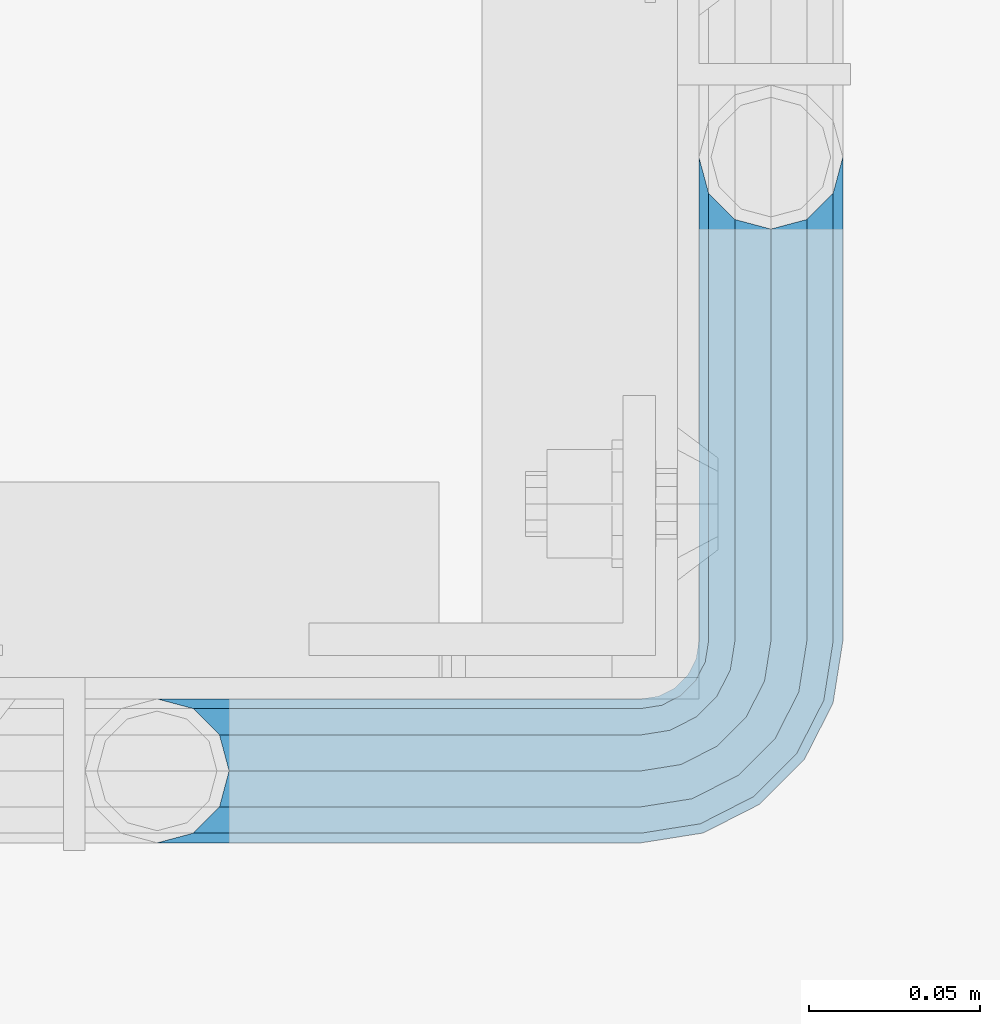
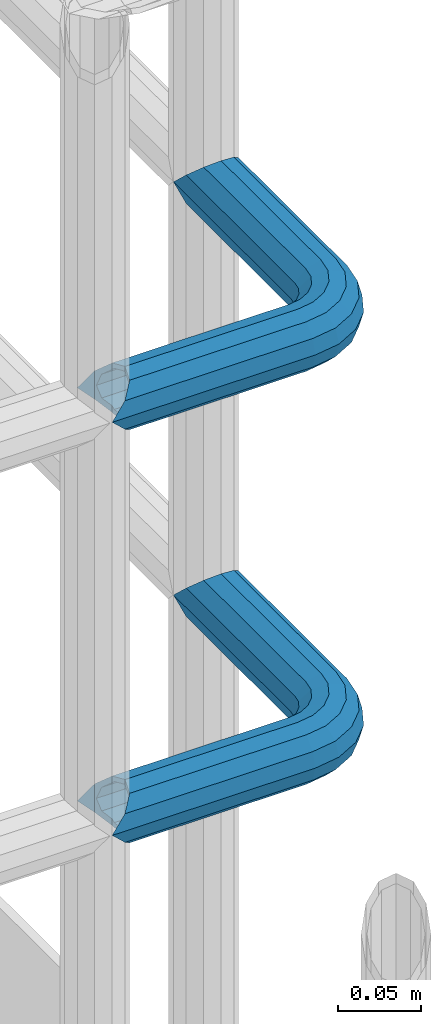
# One storey, part 1119 of 1876: 2 beams, 1 element without a shape of its own.
"""IFC2X3 building model written with IfcOpenShell, lengths in millimetres."""

from ifc_helpers import new_model, si_unit, frame, origin_with_axes, place, context, subcontext, project, spatial, faceted_brep, material, type_object, element, aggregate, save


model = new_model("IFC2X3")

# Units and contexts
model_context = context("Model", 3, precision=1e-05, world=origin_with_axes())
body_context = subcontext(model_context, "Body", "Model", "MODEL_VIEW")
ifc_project = project(units=[si_unit("LENGTHUNIT", "METRE", prefix="MILLI"), si_unit("AREAUNIT", "SQUARE_METRE"), si_unit("VOLUMEUNIT", "CUBIC_METRE"), si_unit("MASSUNIT", "GRAM", prefix="KILO"), si_unit("TIMEUNIT", "SECOND"), si_unit("PLANEANGLEUNIT", "RADIAN"), si_unit("SOLIDANGLEUNIT", "STERADIAN"), si_unit("THERMODYNAMICTEMPERATUREUNIT", "DEGREE_CELSIUS"), si_unit("LUMINOUSINTENSITYUNIT", "LUMEN")], contexts=[model_context])

# Site, building, storey
site_placement = place(None, origin_with_axes())
site = spatial("IfcSite", under=ifc_project, at=site_placement, CompositionType="ELEMENT")
building_placement = place(site_placement, origin_with_axes())
building = spatial("IfcBuilding", under=site, at=building_placement, Name="Undefined", CompositionType="ELEMENT")
storey_placement = place(building_placement, origin_with_axes())
storey = spatial("IfcBuildingStorey", under=building, at=storey_placement, Name="Undefined", CompositionType="ELEMENT", Elevation=0.0)

# Assembly, beams
assembly_placement = place(storey_placement, origin_with_axes())
assembly = element("IfcElementAssembly", 1, at=assembly_placement, inside=storey, Name="HANDRAIL", AssemblyPlace="NOTDEFINED", PredefinedType="RIGID_FRAME")
ifc_material = material()
beam_type = type_object("IfcBeamType", Name="PIPE1-1/4STD", PredefinedType="NOTDEFINED")
beam_1_placement = place(assembly_placement, frame((6845.30474593762, -11381.1963554687, 8480.425), z_axis=(0.0, 0.0, -1.0), x_axis=(1.0, 0.0, 0.0)))
beam_1 = element("IfcBeam", 2, at=beam_1_placement, type_object=beam_type, material=ifc_material, Name="HANDRAIL", ObjectType="PIPE1-1/4STD", context=body_context, shape_type="Brep", body=[
    faceted_brep([(158.747132080079, -179.832000732422, 1.81898940354586e-12), (161.571584517495, -169.290999999999, -10.5409999999974), (161.571584517495, -169.290999999999, 10.5410000000029), (188.592132080079, -161.098037455637, -15.1779612267237), (179.829132080079, -158.749999999998, -17.525999999998), (179.829132080079, -158.749999999998, -21.0819999999985), (190.370132080079, -161.574452437415, -18.2575475625817), (190.370136997563, -161.574452437415, -13.3999563092402), (171.066132080079, -161.098040090908, -15.1779612267237), (169.288136997563, -161.574452437415, -13.3999661442085), (169.288132080079, -161.574452437415, -18.2575475625817), (164.651170853354, -166.211418581624, -8.76299999999719), (162.303132080079, -168.559457354899, 1.81898940354586e-12), (164.651170853354, -166.211418581624, 8.76300000000265), (169.288136997563, -161.574452437415, 13.3999661442122), (169.288132080079, -161.574452437415, 18.2575475625854), (171.066132080079, -161.098040090908, 15.1779612267292), (179.829132080079, -158.749999999998, 17.5260000000017), (179.829132080079, -158.749999999998, 21.0820000000022), (188.592132080079, -161.098037455637, 15.1779612267292), (190.370136997563, -161.574452437415, 13.3999563092439), (190.370132080079, -161.574452437415, 18.2575475625854), (200.911136997564, -179.831999999999, 1.81898940354586e-12), (198.086679642663, -169.290999999999, 10.5410000000029), (198.086679642663, -169.290999999999, -10.5409999999974), (195.007093306805, -166.211408746656, 8.76300000000265), (197.355132080079, -168.55944751993, 1.81898940354586e-12), (195.007093306805, -166.211408746656, -8.76299999999719), (141.729133605959, 21.0819999999967, 3.63797880709171e-12), (141.72913360596, 18.2575475625799, -10.5409999999956), (10.5409999957128, 18.2575475579433, -10.5409999999993), (9.09494701772928e-13, 21.0820000000003, 0.0), (10.5409999999983, 18.2575475625836, 10.5410000000011), (141.729133605959, 18.2575475625799, 10.5410000000047), (141.729133605959, 10.5409999999974, 18.2575475625872), (18.2575475625817, 10.5409999999993, 18.2575475625836), (141.729133605958, -3.63797880709171e-12, 21.082000000004), (21.0819999999985, 1.81898940354586e-12, 21.0820000000003), (141.729133605958, -21.0820000000022, 3.63797880709171e-12), (141.729133605959, -18.2575475625872, -10.5409999999956), (147.860788147674, -19.2287062354389, -10.5409999999956), (146.987984344709, -21.9149201310101, 3.63797880709171e-12), (141.729133605958, -18.2575475625872, 10.5410000000047), (147.860788147674, -19.2287062354389, 10.5410000000047), (141.729133605958, -10.5410000000029, 18.2575475625872), (150.245332482414, -11.8898333927427, 18.2575475625872), (153.50268062012, -1.86474665447531, 21.082000000004), (156.760028757826, 8.16034008379211, 18.257547562589), (159.144573092567, 15.4992129264883, 10.5410000000047), (160.017376895533, 18.1854268220595, 5.45696821063757e-12), (159.144573092567, 15.4992129264883, -10.5409999999956), (141.72913360596, 10.5409999999974, -18.2575475625799), (156.760028757827, 8.16034008379211, -18.2575475625781), (141.729133605959, -3.63797880709171e-12, -21.0819999999949), (153.502680620121, -1.86474665447531, -21.0819999999949), (141.729133605959, -10.5410000000029, -18.2575475625799), (150.245332482415, -11.8898333927427, -18.2575475625781), (190.370132080081, -38.0999984741229, -18.2575475625781), (198.086679642664, -38.0999984741247, -10.5409999999956), (179.829132080081, -38.0999984741229, -21.0819999999949), (169.288132080081, -38.0999984741247, -18.2575475625781), (161.571584517497, -38.0999984741247, -10.5409999999956), (158.747132080079, -38.0999984741247, 5.45696821063757e-12), (161.571584517496, -38.0999984741247, 10.5410000000047), (169.28813208008, -38.0999984741247, 18.257547562589), (179.82913208008, -38.0999984741247, 21.082000000004), (190.37013208008, -38.0999984741247, 18.257547562589), (198.086679642664, -38.0999984741247, 10.5410000000047), (200.91113208008, -38.0999984741247, 5.45696821063757e-12), (198.014558902142, -19.8117551845498, 5.45696821063757e-12), (195.328345006572, -20.6845589875156, -10.5409999999938), (195.328345006572, -20.6845589875156, 10.5410000000047), (187.989472163875, -23.0691033222574, 18.257547562589), (177.964385425607, -26.3264514599632, 21.0820000000058), (167.93929868734, -29.583799597669, 18.257547562589), (160.600425844644, -31.968343932409, 10.5410000000047), (157.914211949073, -32.8411477353748, 5.45696821063757e-12), (160.600425844644, -31.968343932409, -10.5409999999956), (167.939298687341, -29.583799597669, -18.2575475625781), (177.964385425608, -26.3264514599614, -21.0819999999949), (187.989472163876, -23.0691033222556, -18.2575475625781), (187.323346110924, -4.97386405835823, -10.5409999999938), (181.080527994891, -9.50953691425821, -18.2575475625781), (189.608376132597, -3.31369256984362, 5.45696821063757e-12), (187.323346110923, -4.97386405835823, 10.5410000000047), (181.08052799489, -9.50953691425821, 18.257547562589), (172.552679857184, -15.7053812586728, 21.0820000000058), (164.024831719476, -21.9012256030874, 18.257547562589), (157.782013603444, -26.4368984589855, 10.5410000000047), (155.49698358177, -28.0970699475001, 5.45696821063757e-12), (157.782013603444, -26.4368984589855, -10.5409999999956), (164.024831719477, -21.9012256030855, -18.2575475625781), (172.552679857185, -15.705381258671, -21.0819999999949), (170.319595165825, 1.25139591480729, -18.2575475625781), (164.123750821412, -7.27645222289902, -21.0819999999949), (174.855268021725, 7.49421403083943, -10.5409999999956), (176.51543951024, 9.7792440525136, 5.45696821063757e-12), (174.855268021724, 7.49421403083943, 10.5410000000047), (170.319595165825, 1.25139591480729, 18.257547562589), (164.123750821411, -7.27645222289902, 21.0820000000058), (157.927906476996, -15.8043003606053, 18.257547562589), (153.392233621096, -22.0471184766393, 10.5410000000047), (151.732062132583, -24.3321484983135, 3.63797880709171e-12), (153.392233621097, -22.0471184766393, -10.5409999999956), (157.927906476997, -15.8043003606053, -18.2575475625781), (10.5409999957128, -18.2575475672238, -10.5409999999993), (18.2575475625817, -10.5410000000011, -18.2575475625836), (21.0819999999985, 0.0, -21.0819999999985), (18.2575475625817, 10.5409999999993, -18.2575475625836), (141.72913360596, 8.76299999999719, -15.1779612267219), (141.72913360596, 15.1779612267237, -8.76299999999537), (13.6205863358573, 15.1779612267255, -8.76299999999901), (18.2575475625817, 10.5410000000011, -13.3999612267235), (18.7339612267251, 8.76299999999901, -15.1779612267255), (141.729133605959, 17.525999999998, 3.63797880709171e-12), (11.2725475625839, 17.5259999999998, 0.0), (13.6205863358573, 15.1779612267255, 8.76300000000083), (18.2575475625817, 10.5410000000011, 13.3999612267253), (141.729133605959, 15.1779612267237, 8.76300000000447), (141.729133605959, 8.76299999999719, 15.177961226731), (18.7339612267251, 8.76299999999901, 15.1779612267273), (21.0819999999985, 1.81898940354586e-12, 17.5259999999998), (141.729133605958, -3.63797880709171e-12, 17.5260000000035), (141.729133605958, -8.76300000000265, 15.177961226731), (18.7339612267233, -8.76300000000083, 15.1779612267273), (141.729133605958, -15.1779612267292, 8.76300000000447), (141.729133605958, -17.5260000000035, 3.63797880709171e-12), (11.2725475625793, -17.5259999999998, 0.0), (13.6205863358537, -15.1779612267255, 8.76300000000083), (18.2575475625817, -10.5409999999974, 13.3999612267289), (18.2575475625817, -10.5410000000011, 18.2575475625836), (10.5409999999983, -18.2575475625836, 10.5410000000011), (9.09494701772928e-13, -21.0820000000003, 0.0), (13.6205863358537, -15.1779612267255, -8.76299999999901), (18.2575475625817, -10.5409999999974, -13.3999612267271), (141.729133605959, -15.1779612267292, -8.76299999999537), (141.729133605959, -8.76300000000265, -15.1779612267219), (141.729133605959, -3.63797880709171e-12, -17.5259999999962), (21.0819999999985, 0.0, -17.5259999999998), (18.7339612267233, -8.76300000000083, -15.1779612267255), (153.502680620121, -1.86474665447531, -17.5259999999962), (156.210596541829, 6.46936159781944, -15.1779612267219), (158.192928579143, 12.570352274277, -8.76299999999537), (158.918512463535, 14.8034698501142, 5.45696821063757e-12), (158.192928579142, 12.570352274277, 8.76300000000447), (156.210596541828, 6.46936159781944, 15.177961226731), (153.50268062012, -1.86474665447531, 17.5260000000053), (150.794764698413, -10.1988549067701, 15.177961226731), (148.812432661099, -16.2998455832294, 8.76300000000447), (148.086848776706, -18.5329631590648, 3.63797880709171e-12), (148.812432661099, -16.2998455832294, -8.76299999999537), (150.794764698413, -10.1988549067701, -15.1779612267219), (158.972988655572, -14.3658681446068, -15.1779612267219), (164.123750821412, -7.27645222289902, -17.5259999999944), (155.202369052476, -19.5556807952853, -8.76299999999537), (153.822226489734, -21.4552840663146, 5.45696821063757e-12), (155.202369052475, -19.5556807952853, 8.76300000000447), (158.972988655572, -14.3658681446068, 15.177961226731), (164.123750821411, -7.27645222289902, 17.5260000000053), (169.274512987249, -0.187036301191256, 15.177961226731), (173.045132590347, 5.00277634948725, 8.76300000000447), (174.425275153088, 6.90237962051651, 5.45696821063757e-12), (173.045132590347, 5.00277634948725, -8.76299999999537), (169.27451298725, -0.187036301191256, -15.1779612267219), (172.552679857184, -15.705381258671, -17.5259999999944), (179.642095778892, -10.5546190928326, -15.1779612267201), (165.463263935476, -20.8561434245112, -15.1779612267219), (160.273451284798, -24.626763027607, -8.76299999999537), (158.373848013768, -26.0069055903496, 5.45696821063757e-12), (160.273451284797, -24.6267630276088, 8.76300000000447), (165.463263935476, -20.8561434245112, 15.177961226731), (172.552679857184, -15.7053812586728, 17.5260000000053), (179.642095778891, -10.5546190928344, 15.177961226731), (184.83190842957, -6.78399948973674, 8.76300000000447), (186.7315117006, -5.40385692699419, 5.45696821063757e-12), (184.83190842957, -6.78399948973674, -8.76299999999537), (186.298493677902, -23.6185355382549, -15.1779612267201), (192.399484354361, -21.6362035009406, -8.76299999999537), (177.964385425608, -26.3264514599614, -17.5259999999944), (169.630277173314, -29.0343673816697, -15.1779612267219), (163.529286496855, -31.016699418984, -8.76299999999537), (161.296168921019, -31.7422833033779, 5.45696821063757e-12), (163.529286496854, -31.016699418984, 8.76300000000447), (169.630277173313, -29.0343673816697, 15.177961226731), (177.964385425607, -26.3264514599632, 17.5260000000053), (186.298493677902, -23.6185355382549, 15.177961226731), (192.399484354361, -21.6362035009406, 8.76300000000447), (194.632601930197, -20.9106196165467, 5.45696821063757e-12), (195.007093306806, -38.0999984741247, -8.76299999999537), (197.355132080081, -38.0999984741247, 5.45696821063757e-12), (188.592132080081, -38.0999984741229, -15.1779612267219), (179.829132080081, -38.0999984741229, -17.5259999999944), (171.066132080081, -38.0999984741247, -15.1779612267219), (164.651170853354, -38.0999984741247, -8.76299999999537), (162.303132080079, -38.0999984741247, 5.45696821063757e-12), (164.651170853354, -38.0999984741247, 8.76300000000447), (171.06613208008, -38.0999984741247, 15.177961226731), (179.82913208008, -38.0999984741247, 17.5260000000053), (188.59213208008, -38.0999984741247, 15.177961226731), (195.007093306806, -38.0999984741247, 8.76300000000447)], [[[0, 1, 2]], [[3, 4, 5, 6, 7]], [[8, 9, 10, 5, 4]], [[2, 1, 10, 9, 11, 12, 13, 14, 15]], [[15, 14, 16, 17, 18]], [[18, 17, 19, 20, 21]], [[22, 23, 24]], [[21, 20, 25, 26, 27, 7, 6, 24, 23]], [[28, 29, 30, 31]], [[31, 30, 32]], [[33, 28, 31, 32]], [[34, 33, 32, 35]], [[36, 34, 35, 37]], [[38, 39, 40, 41]], [[42, 38, 41, 43]], [[44, 42, 43, 45]], [[36, 44, 45, 46]], [[34, 36, 46, 47]], [[33, 34, 47, 48]], [[28, 33, 48, 49]], [[29, 28, 49, 50]], [[51, 29, 50, 52]], [[53, 51, 52, 54]], [[55, 53, 54, 56]], [[57, 58, 24, 6]], [[59, 57, 6, 5]], [[60, 59, 5, 10]], [[61, 60, 10, 1]], [[62, 61, 1, 0]], [[63, 62, 0, 2]], [[64, 63, 2, 15]], [[65, 64, 15, 18]], [[66, 65, 18, 21]], [[67, 66, 21, 23]], [[68, 67, 23, 22]], [[58, 68, 22, 24]], [[69, 68, 58, 70]], [[71, 67, 68, 69]], [[72, 66, 67, 71]], [[73, 65, 66, 72]], [[74, 64, 65, 73]], [[75, 63, 64, 74]], [[76, 62, 63, 75]], [[77, 61, 62, 76]], [[78, 60, 61, 77]], [[79, 59, 60, 78]], [[80, 57, 59, 79]], [[70, 58, 57, 80]], [[81, 70, 80, 82]], [[83, 69, 70, 81]], [[84, 71, 69, 83]], [[85, 72, 71, 84]], [[86, 73, 72, 85]], [[87, 74, 73, 86]], [[88, 75, 74, 87]], [[89, 76, 75, 88]], [[90, 77, 76, 89]], [[91, 78, 77, 90]], [[92, 79, 78, 91]], [[82, 80, 79, 92]], [[93, 82, 92, 94]], [[95, 81, 82, 93]], [[96, 83, 81, 95]], [[97, 84, 83, 96]], [[98, 85, 84, 97]], [[99, 86, 85, 98]], [[100, 87, 86, 99]], [[101, 88, 87, 100]], [[102, 89, 88, 101]], [[103, 90, 89, 102]], [[104, 91, 90, 103]], [[94, 92, 91, 104]], [[54, 94, 104, 56]], [[52, 93, 94, 54]], [[50, 95, 93, 52]], [[49, 96, 95, 50]], [[48, 97, 96, 49]], [[47, 98, 97, 48]], [[46, 99, 98, 47]], [[45, 100, 99, 46]], [[43, 101, 100, 45]], [[41, 102, 101, 43]], [[40, 103, 102, 41]], [[56, 104, 103, 40]], [[39, 55, 56, 40]], [[55, 39, 105, 106]], [[53, 55, 106, 107]], [[51, 53, 107, 108]], [[29, 51, 108, 30]], [[109, 110, 111, 112, 113]], [[110, 114, 115, 111]], [[32, 30, 108, 112, 111, 115, 116, 117, 35]], [[114, 118, 116, 115]], [[116, 118, 119, 120, 117]], [[35, 117, 120, 121, 37]], [[119, 122, 121, 120]], [[122, 123, 124, 121]], [[125, 126, 127, 128]], [[123, 125, 128, 129, 124]], [[37, 121, 124, 129, 130]], [[44, 36, 37, 130]], [[42, 44, 130, 131]], [[38, 42, 131, 132]], [[39, 38, 132, 105]], [[131, 105, 132]], [[130, 129, 128, 127, 133, 134, 106, 105, 131]], [[126, 135, 133, 127]], [[136, 137, 138, 139]], [[133, 135, 136, 139, 134]], [[138, 107, 106, 134, 139]], [[113, 112, 108, 107, 138]], [[137, 109, 113, 138]], [[109, 137, 140, 141]], [[110, 109, 141, 142]], [[114, 110, 142, 143]], [[118, 114, 143, 144]], [[119, 118, 144, 145]], [[122, 119, 145, 146]], [[123, 122, 146, 147]], [[125, 123, 147, 148]], [[126, 125, 148, 149]], [[135, 126, 149, 150]], [[136, 135, 150, 151]], [[137, 136, 151, 140]], [[151, 152, 153, 140]], [[150, 154, 152, 151]], [[149, 155, 154, 150]], [[148, 156, 155, 149]], [[147, 157, 156, 148]], [[146, 158, 157, 147]], [[145, 159, 158, 146]], [[144, 160, 159, 145]], [[143, 161, 160, 144]], [[142, 162, 161, 143]], [[141, 163, 162, 142]], [[140, 153, 163, 141]], [[153, 164, 165, 163]], [[152, 166, 164, 153]], [[154, 167, 166, 152]], [[155, 168, 167, 154]], [[156, 169, 168, 155]], [[157, 170, 169, 156]], [[158, 171, 170, 157]], [[159, 172, 171, 158]], [[160, 173, 172, 159]], [[161, 174, 173, 160]], [[162, 175, 174, 161]], [[163, 165, 175, 162]], [[165, 176, 177, 175]], [[164, 178, 176, 165]], [[166, 179, 178, 164]], [[167, 180, 179, 166]], [[168, 181, 180, 167]], [[169, 182, 181, 168]], [[170, 183, 182, 169]], [[171, 184, 183, 170]], [[172, 185, 184, 171]], [[173, 186, 185, 172]], [[174, 187, 186, 173]], [[175, 177, 187, 174]], [[177, 188, 189, 187]], [[176, 190, 188, 177]], [[178, 191, 190, 176]], [[179, 192, 191, 178]], [[180, 193, 192, 179]], [[181, 194, 193, 180]], [[182, 195, 194, 181]], [[183, 196, 195, 182]], [[184, 197, 196, 183]], [[185, 198, 197, 184]], [[186, 199, 198, 185]], [[187, 189, 199, 186]], [[199, 189, 26, 25]], [[19, 198, 199, 25, 20]], [[197, 198, 19, 17]], [[196, 197, 17, 16]], [[13, 195, 196, 16, 14]], [[194, 195, 13, 12]], [[193, 194, 12, 11]], [[192, 193, 11, 9, 8]], [[191, 192, 8, 4]], [[190, 191, 4, 3]], [[188, 190, 3, 7, 27]], [[189, 188, 27, 26]]]),
])
beam_2_placement = place(assembly_placement, frame((6845.30474593762, -11381.1963554687, 8785.225), z_axis=(0.0, 0.0, -1.0), x_axis=(1.0, 0.0, 0.0)))
beam_2 = element("IfcBeam", 3, at=beam_2_placement, type_object=beam_type, material=ifc_material, Name="HANDRAIL", ObjectType="PIPE1-1/4STD", context=body_context, shape_type="Brep", body=[
    faceted_brep([(158.747132080079, -179.832000732422, 1.81898940354586e-12), (161.571584517495, -169.290999999999, -10.5409999999974), (161.571584517495, -169.290999999999, 10.5410000000029), (188.592132080079, -161.098037455637, -15.1779612267237), (179.829132080079, -158.749999999998, -17.525999999998), (179.829132080079, -158.749999999998, -21.0819999999985), (190.370132080079, -161.574452437415, -18.2575475625817), (190.370136997563, -161.574452437415, -13.3999563092402), (171.066132080079, -161.098040090908, -15.1779612267237), (169.288136997563, -161.574452437415, -13.3999661442085), (169.288132080079, -161.574452437415, -18.2575475625817), (164.651170853354, -166.211418581624, -8.76299999999719), (162.303132080079, -168.559457354899, 1.81898940354586e-12), (164.651170853354, -166.211418581624, 8.76300000000265), (169.288136997563, -161.574452437415, 13.3999661442122), (169.288132080079, -161.574452437415, 18.2575475625854), (171.066132080079, -161.098040090908, 15.1779612267292), (179.829132080079, -158.749999999998, 17.5260000000017), (179.829132080079, -158.749999999998, 21.0820000000022), (188.592132080079, -161.098037455637, 15.1779612267292), (190.370136997563, -161.574452437415, 13.3999563092439), (190.370132080079, -161.574452437415, 18.2575475625854), (200.911136997564, -179.831999999999, 1.81898940354586e-12), (198.086679642663, -169.290999999999, 10.5410000000029), (198.086679642663, -169.290999999999, -10.5409999999974), (195.007093306805, -166.211408746656, 8.76300000000265), (197.355132080079, -168.55944751993, 1.81898940354586e-12), (195.007093306805, -166.211408746656, -8.76299999999719), (141.729133605959, 21.0819999999967, 3.63797880709171e-12), (141.72913360596, 18.2575475625799, -10.5409999999956), (10.5409999957128, 18.2575475579433, -10.5409999999993), (9.09494701772928e-13, 21.0820000000003, 0.0), (10.5409999999983, 18.2575475625836, 10.5410000000011), (141.729133605959, 18.2575475625799, 10.5410000000047), (141.729133605959, 10.5409999999974, 18.2575475625872), (18.2575475625817, 10.5409999999993, 18.2575475625836), (141.729133605958, -3.63797880709171e-12, 21.082000000004), (21.0819999999985, 1.81898940354586e-12, 21.0820000000003), (141.729133605958, -21.0820000000022, 3.63797880709171e-12), (141.729133605959, -18.2575475625872, -10.5409999999956), (147.860788147674, -19.2287062354389, -10.5409999999956), (146.987984344709, -21.9149201310101, 3.63797880709171e-12), (141.729133605958, -18.2575475625872, 10.5410000000047), (147.860788147674, -19.2287062354389, 10.5410000000047), (141.729133605958, -10.5410000000029, 18.2575475625872), (150.245332482414, -11.8898333927427, 18.2575475625872), (153.50268062012, -1.86474665447531, 21.082000000004), (156.760028757826, 8.16034008379211, 18.257547562589), (159.144573092567, 15.4992129264883, 10.5410000000047), (160.017376895533, 18.1854268220595, 5.45696821063757e-12), (159.144573092567, 15.4992129264883, -10.5409999999956), (141.72913360596, 10.5409999999974, -18.2575475625799), (156.760028757827, 8.16034008379211, -18.2575475625781), (141.729133605959, -3.63797880709171e-12, -21.0819999999949), (153.502680620121, -1.86474665447531, -21.0819999999949), (141.729133605959, -10.5410000000029, -18.2575475625799), (150.245332482415, -11.8898333927427, -18.2575475625781), (190.370132080081, -38.0999984741229, -18.2575475625781), (198.086679642664, -38.0999984741247, -10.5409999999956), (179.829132080081, -38.0999984741229, -21.0819999999949), (169.288132080081, -38.0999984741247, -18.2575475625781), (161.571584517497, -38.0999984741247, -10.5409999999956), (158.747132080079, -38.0999984741247, 5.45696821063757e-12), (161.571584517496, -38.0999984741247, 10.5410000000047), (169.28813208008, -38.0999984741247, 18.257547562589), (179.82913208008, -38.0999984741247, 21.082000000004), (190.37013208008, -38.0999984741247, 18.257547562589), (198.086679642664, -38.0999984741247, 10.5410000000047), (200.91113208008, -38.0999984741247, 5.45696821063757e-12), (198.014558902142, -19.8117551845498, 5.45696821063757e-12), (195.328345006572, -20.6845589875156, -10.5409999999938), (195.328345006572, -20.6845589875156, 10.5410000000047), (187.989472163875, -23.0691033222574, 18.257547562589), (177.964385425607, -26.3264514599632, 21.0820000000058), (167.93929868734, -29.583799597669, 18.257547562589), (160.600425844644, -31.968343932409, 10.5410000000047), (157.914211949073, -32.8411477353748, 5.45696821063757e-12), (160.600425844644, -31.968343932409, -10.5409999999956), (167.939298687341, -29.583799597669, -18.2575475625781), (177.964385425608, -26.3264514599614, -21.0819999999949), (187.989472163876, -23.0691033222556, -18.2575475625781), (187.323346110924, -4.97386405835823, -10.5409999999938), (181.080527994891, -9.50953691425821, -18.2575475625781), (189.608376132597, -3.31369256984362, 5.45696821063757e-12), (187.323346110923, -4.97386405835823, 10.5410000000047), (181.08052799489, -9.50953691425821, 18.257547562589), (172.552679857184, -15.7053812586728, 21.0820000000058), (164.024831719476, -21.9012256030874, 18.257547562589), (157.782013603444, -26.4368984589855, 10.5410000000047), (155.49698358177, -28.0970699475001, 5.45696821063757e-12), (157.782013603444, -26.4368984589855, -10.5409999999956), (164.024831719477, -21.9012256030855, -18.2575475625781), (172.552679857185, -15.705381258671, -21.0819999999949), (170.319595165825, 1.25139591480729, -18.2575475625781), (164.123750821412, -7.27645222289902, -21.0819999999949), (174.855268021725, 7.49421403083943, -10.5409999999956), (176.51543951024, 9.7792440525136, 5.45696821063757e-12), (174.855268021724, 7.49421403083943, 10.5410000000047), (170.319595165825, 1.25139591480729, 18.257547562589), (164.123750821411, -7.27645222289902, 21.0820000000058), (157.927906476996, -15.8043003606053, 18.257547562589), (153.392233621096, -22.0471184766393, 10.5410000000047), (151.732062132583, -24.3321484983135, 3.63797880709171e-12), (153.392233621097, -22.0471184766393, -10.5409999999956), (157.927906476997, -15.8043003606053, -18.2575475625781), (10.5409999957128, -18.2575475672238, -10.5409999999993), (18.2575475625817, -10.5410000000011, -18.2575475625836), (21.0819999999985, 0.0, -21.0819999999985), (18.2575475625817, 10.5409999999993, -18.2575475625836), (141.72913360596, 8.76299999999719, -15.1779612267219), (141.72913360596, 15.1779612267237, -8.76299999999537), (13.6205863358573, 15.1779612267255, -8.76299999999901), (18.2575475625817, 10.5410000000011, -13.3999612267235), (18.7339612267251, 8.76299999999901, -15.1779612267255), (141.729133605959, 17.525999999998, 3.63797880709171e-12), (11.2725475625839, 17.5259999999998, 0.0), (13.6205863358573, 15.1779612267255, 8.76300000000083), (18.2575475625817, 10.5410000000011, 13.3999612267253), (141.729133605959, 15.1779612267237, 8.76300000000447), (141.729133605959, 8.76299999999719, 15.177961226731), (18.7339612267251, 8.76299999999901, 15.1779612267273), (21.0819999999985, 1.81898940354586e-12, 17.5259999999998), (141.729133605958, -3.63797880709171e-12, 17.5260000000035), (141.729133605958, -8.76300000000265, 15.177961226731), (18.7339612267233, -8.76300000000083, 15.1779612267273), (141.729133605958, -15.1779612267292, 8.76300000000447), (141.729133605958, -17.5260000000035, 3.63797880709171e-12), (11.2725475625793, -17.5259999999998, 0.0), (13.6205863358537, -15.1779612267255, 8.76300000000083), (18.2575475625817, -10.5409999999974, 13.3999612267289), (18.2575475625817, -10.5410000000011, 18.2575475625836), (10.5409999999983, -18.2575475625836, 10.5410000000011), (9.09494701772928e-13, -21.0820000000003, 0.0), (13.6205863358537, -15.1779612267255, -8.76299999999901), (18.2575475625817, -10.5409999999974, -13.3999612267271), (141.729133605959, -15.1779612267292, -8.76299999999537), (141.729133605959, -8.76300000000265, -15.1779612267219), (141.729133605959, -3.63797880709171e-12, -17.5259999999962), (21.0819999999985, 0.0, -17.5259999999998), (18.7339612267233, -8.76300000000083, -15.1779612267255), (153.502680620121, -1.86474665447531, -17.5259999999962), (156.210596541829, 6.46936159781944, -15.1779612267219), (158.192928579143, 12.570352274277, -8.76299999999537), (158.918512463535, 14.8034698501142, 5.45696821063757e-12), (158.192928579142, 12.570352274277, 8.76300000000447), (156.210596541828, 6.46936159781944, 15.177961226731), (153.50268062012, -1.86474665447531, 17.5260000000053), (150.794764698413, -10.1988549067701, 15.177961226731), (148.812432661099, -16.2998455832294, 8.76300000000447), (148.086848776706, -18.5329631590648, 3.63797880709171e-12), (148.812432661099, -16.2998455832294, -8.76299999999537), (150.794764698413, -10.1988549067701, -15.1779612267219), (158.972988655572, -14.3658681446068, -15.1779612267219), (164.123750821412, -7.27645222289902, -17.5259999999944), (155.202369052476, -19.5556807952853, -8.76299999999537), (153.822226489734, -21.4552840663146, 5.45696821063757e-12), (155.202369052475, -19.5556807952853, 8.76300000000447), (158.972988655572, -14.3658681446068, 15.177961226731), (164.123750821411, -7.27645222289902, 17.5260000000053), (169.274512987249, -0.187036301191256, 15.177961226731), (173.045132590347, 5.00277634948725, 8.76300000000447), (174.425275153088, 6.90237962051651, 5.45696821063757e-12), (173.045132590347, 5.00277634948725, -8.76299999999537), (169.27451298725, -0.187036301191256, -15.1779612267219), (172.552679857184, -15.705381258671, -17.5259999999944), (179.642095778892, -10.5546190928326, -15.1779612267201), (165.463263935476, -20.8561434245112, -15.1779612267219), (160.273451284798, -24.626763027607, -8.76299999999537), (158.373848013768, -26.0069055903496, 5.45696821063757e-12), (160.273451284797, -24.6267630276088, 8.76300000000447), (165.463263935476, -20.8561434245112, 15.177961226731), (172.552679857184, -15.7053812586728, 17.5260000000053), (179.642095778891, -10.5546190928344, 15.177961226731), (184.83190842957, -6.78399948973674, 8.76300000000447), (186.7315117006, -5.40385692699419, 5.45696821063757e-12), (184.83190842957, -6.78399948973674, -8.76299999999537), (186.298493677902, -23.6185355382549, -15.1779612267201), (192.399484354361, -21.6362035009406, -8.76299999999537), (177.964385425608, -26.3264514599614, -17.5259999999944), (169.630277173314, -29.0343673816697, -15.1779612267219), (163.529286496855, -31.016699418984, -8.76299999999537), (161.296168921019, -31.7422833033779, 5.45696821063757e-12), (163.529286496854, -31.016699418984, 8.76300000000447), (169.630277173313, -29.0343673816697, 15.177961226731), (177.964385425607, -26.3264514599632, 17.5260000000053), (186.298493677902, -23.6185355382549, 15.177961226731), (192.399484354361, -21.6362035009406, 8.76300000000447), (194.632601930197, -20.9106196165467, 5.45696821063757e-12), (195.007093306806, -38.0999984741247, -8.76299999999537), (197.355132080081, -38.0999984741247, 5.45696821063757e-12), (188.592132080081, -38.0999984741229, -15.1779612267219), (179.829132080081, -38.0999984741229, -17.5259999999944), (171.066132080081, -38.0999984741247, -15.1779612267219), (164.651170853354, -38.0999984741247, -8.76299999999537), (162.303132080079, -38.0999984741247, 5.45696821063757e-12), (164.651170853354, -38.0999984741247, 8.76300000000447), (171.06613208008, -38.0999984741247, 15.177961226731), (179.82913208008, -38.0999984741247, 17.5260000000053), (188.59213208008, -38.0999984741247, 15.177961226731), (195.007093306806, -38.0999984741247, 8.76300000000447)], [[[0, 1, 2]], [[3, 4, 5, 6, 7]], [[8, 9, 10, 5, 4]], [[2, 1, 10, 9, 11, 12, 13, 14, 15]], [[15, 14, 16, 17, 18]], [[18, 17, 19, 20, 21]], [[22, 23, 24]], [[21, 20, 25, 26, 27, 7, 6, 24, 23]], [[28, 29, 30, 31]], [[31, 30, 32]], [[33, 28, 31, 32]], [[34, 33, 32, 35]], [[36, 34, 35, 37]], [[38, 39, 40, 41]], [[42, 38, 41, 43]], [[44, 42, 43, 45]], [[36, 44, 45, 46]], [[34, 36, 46, 47]], [[33, 34, 47, 48]], [[28, 33, 48, 49]], [[29, 28, 49, 50]], [[51, 29, 50, 52]], [[53, 51, 52, 54]], [[55, 53, 54, 56]], [[57, 58, 24, 6]], [[59, 57, 6, 5]], [[60, 59, 5, 10]], [[61, 60, 10, 1]], [[62, 61, 1, 0]], [[63, 62, 0, 2]], [[64, 63, 2, 15]], [[65, 64, 15, 18]], [[66, 65, 18, 21]], [[67, 66, 21, 23]], [[68, 67, 23, 22]], [[58, 68, 22, 24]], [[69, 68, 58, 70]], [[71, 67, 68, 69]], [[72, 66, 67, 71]], [[73, 65, 66, 72]], [[74, 64, 65, 73]], [[75, 63, 64, 74]], [[76, 62, 63, 75]], [[77, 61, 62, 76]], [[78, 60, 61, 77]], [[79, 59, 60, 78]], [[80, 57, 59, 79]], [[70, 58, 57, 80]], [[81, 70, 80, 82]], [[83, 69, 70, 81]], [[84, 71, 69, 83]], [[85, 72, 71, 84]], [[86, 73, 72, 85]], [[87, 74, 73, 86]], [[88, 75, 74, 87]], [[89, 76, 75, 88]], [[90, 77, 76, 89]], [[91, 78, 77, 90]], [[92, 79, 78, 91]], [[82, 80, 79, 92]], [[93, 82, 92, 94]], [[95, 81, 82, 93]], [[96, 83, 81, 95]], [[97, 84, 83, 96]], [[98, 85, 84, 97]], [[99, 86, 85, 98]], [[100, 87, 86, 99]], [[101, 88, 87, 100]], [[102, 89, 88, 101]], [[103, 90, 89, 102]], [[104, 91, 90, 103]], [[94, 92, 91, 104]], [[54, 94, 104, 56]], [[52, 93, 94, 54]], [[50, 95, 93, 52]], [[49, 96, 95, 50]], [[48, 97, 96, 49]], [[47, 98, 97, 48]], [[46, 99, 98, 47]], [[45, 100, 99, 46]], [[43, 101, 100, 45]], [[41, 102, 101, 43]], [[40, 103, 102, 41]], [[56, 104, 103, 40]], [[39, 55, 56, 40]], [[55, 39, 105, 106]], [[53, 55, 106, 107]], [[51, 53, 107, 108]], [[29, 51, 108, 30]], [[109, 110, 111, 112, 113]], [[110, 114, 115, 111]], [[32, 30, 108, 112, 111, 115, 116, 117, 35]], [[114, 118, 116, 115]], [[116, 118, 119, 120, 117]], [[35, 117, 120, 121, 37]], [[119, 122, 121, 120]], [[122, 123, 124, 121]], [[125, 126, 127, 128]], [[123, 125, 128, 129, 124]], [[37, 121, 124, 129, 130]], [[44, 36, 37, 130]], [[42, 44, 130, 131]], [[38, 42, 131, 132]], [[39, 38, 132, 105]], [[131, 105, 132]], [[130, 129, 128, 127, 133, 134, 106, 105, 131]], [[126, 135, 133, 127]], [[136, 137, 138, 139]], [[133, 135, 136, 139, 134]], [[138, 107, 106, 134, 139]], [[113, 112, 108, 107, 138]], [[137, 109, 113, 138]], [[109, 137, 140, 141]], [[110, 109, 141, 142]], [[114, 110, 142, 143]], [[118, 114, 143, 144]], [[119, 118, 144, 145]], [[122, 119, 145, 146]], [[123, 122, 146, 147]], [[125, 123, 147, 148]], [[126, 125, 148, 149]], [[135, 126, 149, 150]], [[136, 135, 150, 151]], [[137, 136, 151, 140]], [[151, 152, 153, 140]], [[150, 154, 152, 151]], [[149, 155, 154, 150]], [[148, 156, 155, 149]], [[147, 157, 156, 148]], [[146, 158, 157, 147]], [[145, 159, 158, 146]], [[144, 160, 159, 145]], [[143, 161, 160, 144]], [[142, 162, 161, 143]], [[141, 163, 162, 142]], [[140, 153, 163, 141]], [[153, 164, 165, 163]], [[152, 166, 164, 153]], [[154, 167, 166, 152]], [[155, 168, 167, 154]], [[156, 169, 168, 155]], [[157, 170, 169, 156]], [[158, 171, 170, 157]], [[159, 172, 171, 158]], [[160, 173, 172, 159]], [[161, 174, 173, 160]], [[162, 175, 174, 161]], [[163, 165, 175, 162]], [[165, 176, 177, 175]], [[164, 178, 176, 165]], [[166, 179, 178, 164]], [[167, 180, 179, 166]], [[168, 181, 180, 167]], [[169, 182, 181, 168]], [[170, 183, 182, 169]], [[171, 184, 183, 170]], [[172, 185, 184, 171]], [[173, 186, 185, 172]], [[174, 187, 186, 173]], [[175, 177, 187, 174]], [[177, 188, 189, 187]], [[176, 190, 188, 177]], [[178, 191, 190, 176]], [[179, 192, 191, 178]], [[180, 193, 192, 179]], [[181, 194, 193, 180]], [[182, 195, 194, 181]], [[183, 196, 195, 182]], [[184, 197, 196, 183]], [[185, 198, 197, 184]], [[186, 199, 198, 185]], [[187, 189, 199, 186]], [[199, 189, 26, 25]], [[19, 198, 199, 25, 20]], [[197, 198, 19, 17]], [[196, 197, 17, 16]], [[13, 195, 196, 16, 14]], [[194, 195, 13, 12]], [[193, 194, 12, 11]], [[192, 193, 11, 9, 8]], [[191, 192, 8, 4]], [[190, 191, 4, 3]], [[188, 190, 3, 7, 27]], [[189, 188, 27, 26]]]),
])
aggregate(assembly, [beam_1, beam_2])

save(model, "model.ifc")
